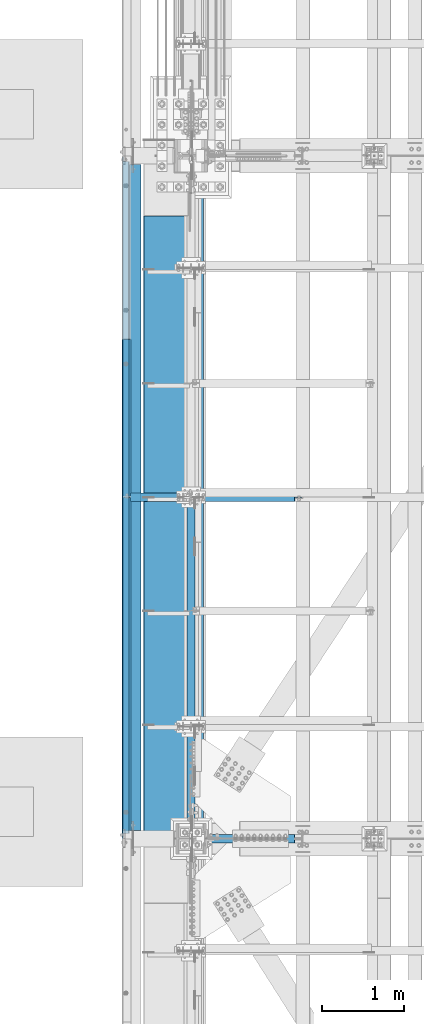
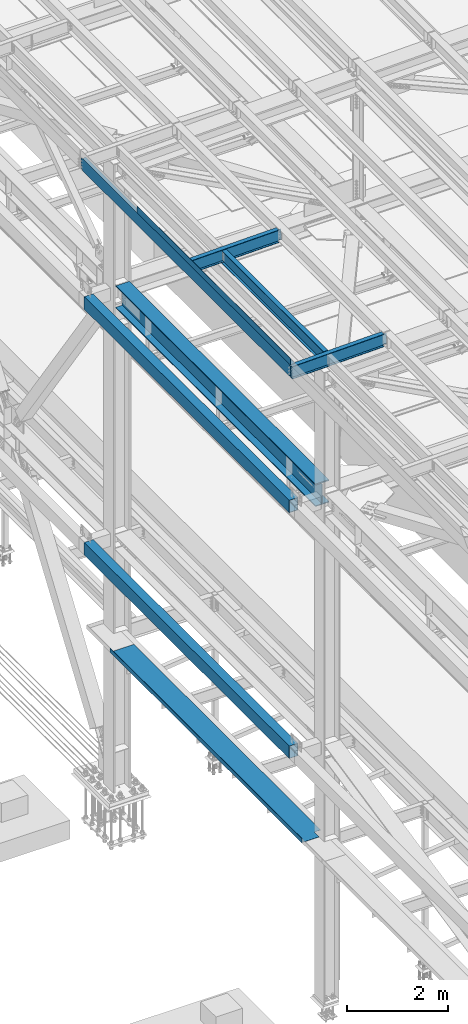
# One storey, part 1808 of 3843: 9 beams, 8 elements without a shape of their own.
"""IFC2X3 building model written with IfcOpenShell, lengths in millimetres."""

from ifc_helpers import new_model, si_unit, frame, origin_with_axes, place, context, subcontext, project, spatial, faceted_brep, material, type_object, element, aggregate, save


model = new_model("IFC2X3")

# Units and contexts
model_context = context("Model", 3, precision=1e-05, world=origin_with_axes())
body_context = subcontext(model_context, "Body", "Model", "MODEL_VIEW")
ifc_project = project(units=[si_unit("LENGTHUNIT", "METRE", prefix="MILLI"), si_unit("AREAUNIT", "SQUARE_METRE"), si_unit("VOLUMEUNIT", "CUBIC_METRE"), si_unit("MASSUNIT", "GRAM", prefix="KILO"), si_unit("TIMEUNIT", "SECOND"), si_unit("PLANEANGLEUNIT", "RADIAN"), si_unit("SOLIDANGLEUNIT", "STERADIAN"), si_unit("THERMODYNAMICTEMPERATUREUNIT", "DEGREE_CELSIUS"), si_unit("LUMINOUSINTENSITYUNIT", "LUMEN")], contexts=[model_context])

# Site, building, storey
site_placement = place(None, origin_with_axes())
site = spatial("IfcSite", under=ifc_project, at=site_placement, CompositionType="ELEMENT")
building_placement = place(site_placement, origin_with_axes())
building = spatial("IfcBuilding", under=site, at=building_placement, Name="Undefined", CompositionType="ELEMENT")
storey_placement = place(building_placement, origin_with_axes())
storey = spatial("IfcBuildingStorey", under=building, at=storey_placement, Name="Undefined", CompositionType="ELEMENT", Elevation=0.0)

# Assembly, beams
assembly_1_placement = place(storey_placement, origin_with_axes())
assembly_1 = element("IfcElementAssembly", 1, at=assembly_1_placement, inside=storey, Name="BEAM", AssemblyPlace="NOTDEFINED", PredefinedType="RIGID_FRAME")
ifc_material_1 = material(Name="STEEL/A572-50")
beam_type_1 = type_object("IfcBeamType", Name="C12X20.7", PredefinedType="NOTDEFINED")
beam_1_placement = place(assembly_1_placement, frame((35779.1150555403, 42202.0999999999, 45560.3009647411), z_axis=(-0.0211520980073474, 0.0, 0.999776269347241), x_axis=(0.0, 1.0, 0.0)))
beam_1 = element("IfcBeam", 2, at=beam_1_placement, type_object=beam_type_1, material=ifc_material_1, Name="BEAM", ObjectType="C12X20.7", context=body_context, shape_type="Brep", body=[
    faceted_brep([(15.8750000000582, 30.1624999998166, -126.999999999382), (15.8750003662499, 38.1000000000058, -127.000000023749), (53.975000190796, 38.0999999998094, -126.999999999396), (53.975000190796, 30.1624999998166, -126.999999999382), (58.8350797088351, 38.0999999998094, -127.96672992198), (58.8350797088351, 30.1624999998166, -127.966729921965), (62.955256176996, 38.0999999998021, -130.719743822439), (62.955256176996, 30.1624999998166, -130.719743822439), (65.7082700774772, 38.0999999997948, -134.839920290578), (65.7082700774772, 30.1624999998094, -134.6749274998), (66.6750000000611, 1.14757131086662e-06, -139.699999808552), (66.6750000000611, 38.0999999997948, -139.699999808603), (66.6750000000611, 38.0999999997803, -152.399999999783), (66.6750000000611, -38.1000000000931, -152.39999999971), (66.6750000000611, -38.1000000000931, -146.047459999718), (8289.92500000005, -38.0999999997948, 146.047459999805), (8289.92500000005, -38.0999999997875, 152.399999999798), (66.6750000000611, -38.0999999997875, 152.399999999798), (66.6750000000611, -38.0999999997948, 146.047459999805), (8289.92500000005, 38.1000000000859, 152.399999999725), (66.6750000000611, 38.1000000000859, 152.399999999725), (53.975000190796, 30.1625000000713, 126.999999999265), (53.975000190796, 38.100000000064, 126.999999999258), (15.8750006201954, 38.1000000000058, 126.999999975014), (15.8750000000582, 30.1625000000713, 126.999999999265), (58.8350797088351, 30.1625000000786, 127.966729921849), (58.8350797088351, 38.100000000064, 127.966729921842), (62.955256176996, 30.1625000000786, 130.719743822316), (62.955256176996, 38.1000000000568, 130.719743822301), (65.7082700774772, 30.1625000000786, 134.674927499756), (65.7082700774772, 38.1000000000713, 134.83992029044), (66.6750000000611, 1.1482770787552e-06, 139.699999808494), (66.6750000000611, 38.1000000000713, 139.699999808465), (8290.89172992263, 30.1625000000786, 134.674927499756), (8289.92500000005, 1.1482770787552e-06, 139.699999808494), (8289.92500000005, 38.1000000000713, 139.699999808465), (8290.89172992263, 38.1000000000713, 134.83992029044), (8293.64474382311, 30.1625000000786, 130.719743822316), (8293.64474382311, 38.1000000000568, 130.719743822301), (8297.76492029126, 30.1625000000786, 127.966729921849), (8297.76492029126, 38.100000000064, 127.966729921842), (8302.62499980931, 30.1625000000713, 126.999999999265), (8302.62499980931, 38.100000000064, 126.999999999258), (8340.72500000005, 30.1625000000713, 126.999999999265), (8340.72500000005, 38.100000000064, 126.999999999258), (8340.72500000005, 30.162500000064, 114.299999983516), (8340.72500000005, 30.1624999998385, -116.300000010502), (8340.72500000005, 30.1624999998166, -126.999999999382), (8340.72500000005, 38.0999999998094, -126.999999999396), (8302.62499980931, 30.1624999998166, -126.999999999382), (8302.62499980931, 38.0999999998094, -126.999999999396), (8297.76492029126, 30.1624999998166, -127.966729921965), (8297.76492029126, 38.0999999998094, -127.96672992198), (8293.64474382311, 30.1624999998166, -130.719743822439), (8293.64474382311, 38.0999999998021, -130.719743822439), (8290.89172992263, 30.1624999998094, -134.6749274998), (8290.89172992263, 38.0999999997948, -134.839920290578), (8289.92500000005, 1.14757131086662e-06, -139.699999808552), (8289.92500000005, 38.0999999997948, -139.699999808603), (8289.92500000005, -38.1000000000931, -146.047459999718), (8289.92500000005, -38.1000000000931, -152.39999999971), (8289.92500000005, 38.0999999997803, -152.399999999783), (15.8750000000582, 30.1624999998312, -116.299999999967), (15.8750000000582, 30.1625000000568, 114.299999994066)], [[[0, 1, 2, 3]], [[3, 2, 4, 5]], [[5, 4, 6, 7]], [[7, 6, 8, 9]], [[10, 11, 12, 13, 14]], [[9, 8, 11, 10]], [[15, 16, 17, 18]], [[16, 19, 20, 17]], [[21, 22, 23, 24]], [[25, 26, 22, 21]], [[27, 28, 26, 25]], [[29, 30, 28, 27]], [[31, 32, 30, 29]], [[17, 20, 32, 31, 18]], [[29, 33, 34, 15, 18, 31]], [[16, 15, 34, 35, 19]], [[33, 36, 35, 34]], [[37, 38, 36, 33]], [[39, 40, 38, 37]], [[41, 42, 40, 39]], [[43, 44, 42, 41]], [[44, 43, 45, 46, 47, 48]], [[47, 49, 50, 48]], [[51, 52, 50, 49]], [[53, 54, 52, 51]], [[55, 56, 54, 53]], [[57, 58, 56, 55]], [[59, 60, 61, 58, 57]], [[60, 59, 14, 13]], [[61, 60, 13, 12]], [[6, 4, 2, 1, 23, 22, 26, 28, 30, 32, 20, 19, 35, 36, 38, 40, 42, 44, 48, 50, 52, 54, 56, 58, 61, 12, 11, 8]], [[62, 63, 24, 23, 1, 0]], [[55, 53, 51, 49, 47, 46, 45, 43, 41, 39, 37, 33, 29, 27, 25, 21, 24, 63, 62, 0, 3, 5, 7, 9]], [[59, 57, 55, 9, 10, 14]]]),
])
ifc_material_2 = material(Name="STEEL/A36")
beam_type_2 = type_object("IfcBeamType", PredefinedType="NOTDEFINED")
beam_2_placement = place(assembly_1_placement, frame((35839.3101109972, 45265.975, 45717.1843160676), z_axis=(0.0, -1.0, 0.0), x_axis=(-0.999776270257024, 0.0, -0.0211520550054595)))
beam_2 = element("IfcBeam", 3, at=beam_2_placement, type_object=beam_type_2, material=ifc_material_2, Name="BENT_PLATE", context=body_context, shape_type="Brep", body=[
    faceted_brep([(-3.50355549016967e-07, -3.17499999742722, -3048.00000001723), (3.50421032635495e-07, -3.17500000260043, 3048.00000001724), (3.5035191103816e-07, 3.17499999739084, 3048.00000001724), (-3.50424670614302e-07, 3.17500000256405, -3048.00000001723), (101.599999864371, 3.17499999856227, 3048.00000000522), (101.599998739839, 3.17500000373548, -3048.00000002925), (95.249998765099, -3.17499999632128, -3048.00000002851), (95.2499998896274, -3.17500000149448, 3048.00000000597), (101.600000309205, -161.925000875126, 3047.9999999938), (101.599999608374, -161.925000446165, -3048.00000004067), (95.2500003092064, -161.925000900388, 3047.99999999456), (95.2499996083752, -161.925000471427, -3048.00000003992)], [[[0, 1, 2, 3]], [[3, 2, 4, 5]], [[1, 0, 6, 7]], [[5, 4, 8, 9]], [[4, 2, 1, 7, 10, 8]], [[7, 6, 11, 10]], [[6, 0, 3, 5, 9, 11]], [[10, 11, 9, 8]]]),
])
aggregate(assembly_1, [beam_2, beam_1])

# Assembly, beam
assembly_2_placement = place(storey_placement, origin_with_axes())
assembly_2 = element("IfcElementAssembly", 4, at=assembly_2_placement, inside=storey, Name="BEAM", AssemblyPlace="NOTDEFINED", PredefinedType="RIGID_FRAME")
ifc_material_3 = material(Name="STEEL/A992")
beam_type_3 = type_object("IfcBeamType", Name="W21X101", PredefinedType="NOTDEFINED")
beam_3_placement = place(assembly_2_placement, frame((36576.0, 42202.1, 42197.3375), z_axis=(0.0, 0.0, 1.0), x_axis=(0.0, 1.0, 0.0)))
beam_3 = element("IfcBeam", 5, at=beam_3_placement, type_object=beam_type_3, material=ifc_material_3, Name="BEAM", ObjectType="W21X101", context=body_context, shape_type="Brep", body=[
    faceted_brep([(8143.87499999999, 155.574999999997, -271.462500000001), (8143.87499999999, 147.637499999997, -271.462500000001), (8143.87499999999, -147.637499999997, -271.462500000001), (8143.87499999999, -155.574999999997, -271.462500000001), (198.4375, -155.574999999997, -271.462500000001), (198.4375, 155.574999999997, -271.462500000001), (8143.87499999999, -155.574999999997, -250.824999999997), (198.4375, -155.574999999997, -250.824999999997), (277.464930772214, -6.34999999999127, 217.357163726287), (277.464930772214, 6.35000000000582, 217.357163726287), (272.401765581464, 6.35000000000582, 215.900000000001), (272.401765581464, -6.34999999999127, 215.900000000001), (280.978938807766, -6.34999999999127, 221.282812131351), (280.978938807766, 6.35000000000582, 221.282812131351), (281.868622181899, -6.34999999999127, 226.475829690324), (281.868622181899, 6.35000000000582, 226.475829690324), (279.861767898796, -6.34999999999127, 231.347328818971), (279.861767898796, 6.35000000000582, 231.347328818971), (275.572405435074, -6.34999999999127, 234.406795689014), (275.572405435074, 6.35000000000582, 234.406795689014), (230.187500000004, -6.34999999999127, 250.428), (230.187500000004, 6.35000000000582, 250.428), (195.262500000001, -6.35000000000582, 250.428), (195.262500000001, 6.35000000000582, 250.428), (195.262500000001, -6.35000000000582, 250.824999999997), (195.262500000001, 6.35000000000582, 250.824999999997), (8143.87499999999, -155.574999999997, 271.462500000001), (8143.87499999999, -147.637499999997, 271.462500000001), (8143.87499999999, 147.637499999997, 271.462500000001), (8143.87499999999, 155.574999999997, 271.462500000001), (207.177101116094, 155.574999999997, 271.462500000001), (207.177101116094, -155.574999999997, 271.462500000001), (8143.87499999999, 155.574999999997, 250.824999999997), (195.262500000001, 155.574999999997, 250.824999999997), (8143.87499999999, 147.637499999997, 250.824999999997), (8143.87499999999, 6.34999999999854, 250.824999999997), (8143.87499999999, 6.34999999999854, -250.824999999997), (8143.87499999999, 147.637499999997, -250.824999999997), (8143.87499999999, 155.574999999997, -250.824999999997), (198.4375, 155.574999999997, -250.824999999997), (198.4375, 6.34999999999854, -250.824999999997), (198.4375, 6.34999999999854, 215.900000000001), (198.4375, -6.34999999999854, 215.900000000001), (8143.87499999999, -6.34999999999854, -250.824999999997), (8143.87499999999, -6.34999999999854, -180.127499999995), (8143.87499999999, -6.34999999999854, 215.052499999998), (8143.87499999999, -6.34999999999854, 250.824999999997), (198.4375, -6.34999999999854, -250.824999999997), (8143.87499999999, -147.637499999997, -250.824999999997), (8143.87499999999, -155.574999999997, 250.824999999997), (8143.87499999999, -147.637499999997, 250.824999999997), (195.262500000001, -155.574999999997, 250.824999999997)], [[[0, 1, 2, 3, 4, 5]], [[3, 6, 7, 4]], [[8, 9, 10, 11]], [[12, 13, 9, 8]], [[14, 15, 13, 12]], [[16, 17, 15, 14]], [[18, 19, 17, 16]], [[20, 21, 19, 18]], [[21, 20, 22, 23]], [[23, 22, 24, 25]], [[26, 27, 28, 29, 30, 31]], [[29, 32, 33, 30]], [[32, 34, 35, 25, 33]], [[36, 37, 38, 39, 40]], [[10, 9, 13, 15, 17, 19, 21, 23, 25, 35, 36, 40, 41]], [[11, 10, 41, 42]], [[43, 44, 45, 46, 24, 22, 20, 18, 16, 14, 12, 8, 11, 42, 47]], [[6, 48, 43, 47, 7]], [[42, 41, 40, 39, 5, 4, 7, 47]], [[38, 0, 5, 39]], [[37, 36, 35, 34, 32, 29, 28, 27, 26, 49, 50, 46, 45, 44, 43, 48, 6, 3, 2, 1, 0, 38]], [[46, 50, 49, 51, 24]], [[31, 30, 33, 25, 24, 51]], [[49, 26, 31, 51]]]),
])
aggregate(assembly_2, [beam_3])

assembly_3_placement = place(storey_placement, origin_with_axes())
assembly_3 = element("IfcElementAssembly", 6, at=assembly_3_placement, inside=storey, Name="GIRT", AssemblyPlace="NOTDEFINED", PredefinedType="RIGID_FRAME")
ifc_material_4 = material()
beam_type_4 = type_object("IfcBeamType", Name="HSS12X8X3/8", PredefinedType="NOTDEFINED")
beam_4_placement = place(assembly_3_placement, frame((35861.625, 42202.1, 42214.8), z_axis=(0.0, 0.0, 1.0), x_axis=(0.0, 1.0, 0.0)))
beam_4 = element("IfcBeam", 7, at=beam_4_placement, type_object=beam_type_4, material=ifc_material_4, Name="GIRT", ObjectType="HSS12X8X3/8", context=body_context, shape_type="Brep", body=[
    faceted_brep([(8253.41249999999, 101.599999999999, -152.400000000001), (8253.41249999999, -101.599999999999, -152.400000000001), (103.1875, -101.600000000006, -152.400000000001), (103.1875, 101.600000000006, -152.400000000001), (8253.41249999999, -101.599999999999, 152.400000000001), (103.1875, -101.600000000006, 152.400000000001), (8253.41249999999, 101.599999999999, 152.400000000001), (103.1875, 101.600000000006, 152.400000000001), (103.1875, 92.0749999999971, -142.875), (103.1875, 92.0749999999971, 142.875), (103.1875, -92.0749999999971, 142.875), (103.1875, -92.0749999999971, -142.875), (8253.41249999999, -92.0749999999971, 142.875), (8253.41249999999, -92.0749999999971, -142.875), (8253.41249999999, 92.0749999999971, -142.875), (8253.41249999999, 92.0749999999971, 142.875)], [[[0, 1, 2, 3]], [[1, 4, 5, 2]], [[4, 6, 7, 5]], [[6, 0, 3, 7]], [[3, 2, 5, 7], [8, 9, 10, 11]], [[12, 13, 11, 10]], [[13, 14, 8, 11]], [[14, 15, 9, 8]], [[15, 12, 10, 9]], [[0, 6, 4, 1], [14, 13, 12, 15]]]),
])
aggregate(assembly_3, [beam_4])

assembly_4_placement = place(storey_placement, origin_with_axes())
assembly_4 = element("IfcElementAssembly", 8, at=assembly_4_placement, inside=storey, Name="GIRT", AssemblyPlace="NOTDEFINED", PredefinedType="RIGID_FRAME")
beam_5_placement = place(assembly_4_placement, frame((35861.625, 42202.1, 36252.15), z_axis=(0.0, 0.0, 1.0), x_axis=(0.0, 1.0, 0.0)))
beam_5 = element("IfcBeam", 9, at=beam_5_placement, type_object=beam_type_4, material=ifc_material_4, Name="GIRT", ObjectType="HSS12X8X3/8", context=body_context, shape_type="Brep", body=[
    faceted_brep([(8253.41249999999, 101.599999999999, -152.400000000001), (8253.41249999999, -101.599999999999, -152.400000000001), (103.1875, -101.600000000006, -152.400000000001), (103.1875, 101.600000000006, -152.400000000001), (8253.41249999999, 101.599999999999, 152.400000000001), (103.1875, 101.600000000006, 152.400000000001), (8253.41249999999, -101.599999999999, 152.400000000001), (103.1875, -101.600000000006, 152.400000000001), (8253.41249999999, 92.0749999999971, -142.875), (8253.41249999999, -92.0749999999971, -142.875), (8253.41249999999, -92.0749999999971, 142.875), (8253.41249999999, 92.0749999999971, 142.875), (103.1875, -92.0749999999971, 142.875), (103.1875, 92.0749999999971, 142.875), (103.1875, 92.0749999999971, -142.875), (103.1875, -92.0749999999971, -142.875)], [[[0, 1, 2, 3]], [[4, 0, 3, 5]], [[6, 4, 5, 7]], [[1, 6, 7, 2]], [[0, 4, 6, 1], [8, 9, 10, 11]], [[11, 10, 12, 13]], [[8, 11, 13, 14]], [[9, 8, 14, 15]], [[10, 9, 15, 12]], [[3, 2, 7, 5], [14, 13, 12, 15]]]),
])
aggregate(assembly_4, [beam_5])

assembly_5_placement = place(storey_placement, origin_with_axes())
assembly_5 = element("IfcElementAssembly", 10, at=assembly_5_placement, inside=storey, Name="BEAM", AssemblyPlace="NOTDEFINED", PredefinedType="RIGID_FRAME")
beam_type_5 = type_object("IfcBeamType", Name="W12X19", PredefinedType="NOTDEFINED")
beam_6_placement = place(assembly_5_placement, frame((36575.9999999361, 42202.1, 45575.6071293687), z_axis=(0.0, 0.0, 1.0), x_axis=(0.0, 1.0, 0.0)))
beam_6 = element("IfcBeam", 11, at=beam_6_placement, type_object=beam_type_5, material=ifc_material_3, Name="BEAM", ObjectType="W12X19", context=body_context, shape_type="Brep", body=[
    faceted_brep([(15.8750000000146, -3.17500000000291, -128.587499998961), (15.8750000000146, 3.17500000000291, -128.587499998961), (53.9750001907523, 3.17500000000291, -128.587499998961), (53.9750001907523, -3.17500000000291, -128.587499998961), (58.8350797087915, 3.17500000000291, -129.554229921552), (58.8350797087915, -3.17500000000291, -129.554229921552), (62.9552561769524, 3.17500000000291, -132.307243822026), (62.9552561769524, -3.17500000000291, -132.307243822026), (65.7082700774336, 3.17500000000291, -136.42742029018), (65.7082700774336, -3.17500000000291, -136.42742029018), (66.6750000000175, -3.17500000000291, -141.287499808226), (66.6750000000175, 3.17500000000291, -141.287499808226), (66.6750000000175, 3.17500000000291, -144.462500000001), (66.6750000000175, 50.8000000000029, -144.462500000001), (66.6750000000175, 50.8000000000029, -153.987500000003), (66.6750000000175, -50.8000000000029, -153.987500000003), (66.6750000000175, -50.8000000000029, -144.462500000001), (66.6750000000175, -3.17500000000291, -144.462500000001), (4111.62499999991, 50.8000000000029, 144.462500000001), (4111.62499999991, 3.17500000000291, 144.462500000001), (66.6750000000175, 3.17500000000291, 144.462500000001), (66.6750000000175, 50.8000000000029, 144.462500000001), (53.9750001907523, -3.17500000000291, 128.587500001042), (53.9750001907523, 3.17500000000291, 128.587500001042), (15.8750000000146, 3.17500000000291, 128.587500001042), (15.8750000000146, -3.17500000000291, 128.587500001042), (58.8350797087915, -3.17500000000291, 129.554229923633), (58.8350797087915, 3.17500000000291, 129.554229923633), (62.9552561769524, -3.17500000000291, 132.307243824107), (62.9552561769524, 3.17500000000291, 132.307243824107), (65.7082700774336, -3.17500000000291, 136.427420292261), (65.7082700774336, 3.17500000000291, 136.427420292261), (66.6750000000175, -3.17500000000291, 141.287499810307), (66.6750000000175, 3.17500000000291, 141.287499810307), (4111.62499999991, -50.8000000000029, 153.987500000003), (4111.62499999991, 50.8000000000029, 153.987500000003), (66.6750000000175, 50.8000000000029, 153.987500000003), (66.6750000000175, -50.8000000000029, 153.987500000003), (4111.62499999991, -50.8000000000029, 144.462500000001), (66.6750000000175, -50.8000000000029, 144.462500000001), (4111.62499999991, -3.17500000000291, 144.462500000001), (66.6750000000175, -3.17500000000291, 144.462500000001), (4111.62499999991, -3.17500000000291, 141.287499810329), (4111.62499999991, 3.17500000000291, 141.287499810329), (4112.5917299225, -3.17500000000291, 136.427420292282), (4112.5917299225, 3.17500000000291, 136.427420292282), (4115.34474382298, -3.17500000000291, 132.307243824129), (4115.34474382298, 3.17500000000291, 132.307243824129), (4119.46492029114, -3.17500000000291, 129.554229923655), (4119.46492029114, 3.17500000000291, 129.554229923655), (4124.32499980918, -3.17500000000291, 128.587500001064), (4124.32499980918, 3.17500000000291, 128.587500001064), (4162.42499999992, -3.17500000000291, 128.587500001064), (4162.42499999992, 3.17500000000291, 128.587500001064), (4162.42499999992, 3.17500000000291, -114.712499998423), (4162.42499999992, 3.17500000000291, 115.887500001576), (4162.42499999992, -3.17500000000291, -128.587499998939), (4162.42499999992, 3.17500000000291, -128.587499998939), (4124.32499980918, -3.17500000000291, -128.587499998939), (4124.32499980918, 3.17500000000291, -128.587499998939), (4119.46492029114, -3.17500000000291, -129.55422992153), (4119.46492029114, 3.17500000000291, -129.55422992153), (4115.34474382298, -3.17500000000291, -132.307243822004), (4115.34474382298, 3.17500000000291, -132.307243822004), (4112.5917299225, -3.17500000000291, -136.427420290158), (4112.5917299225, 3.17500000000291, -136.427420290158), (4111.62499999991, -3.17500000000291, -141.287499808204), (4111.62499999991, 3.17500000000291, -141.287499808204), (4111.62499999991, -3.17500000000291, -144.462500000001), (4111.62499999991, -50.8000000000029, -144.462500000001), (4111.62499999991, -50.8000000000029, -153.987500000003), (4111.62499999991, 50.8000000000029, -153.987500000003), (4111.62499999991, 50.8000000000029, -144.462500000001), (4111.62499999991, 3.17500000000291, -144.462500000001), (15.8750000000146, 3.17500000000291, -114.712499998386), (15.8750000000146, 3.17500000000291, 115.887500001612)], [[[0, 1, 2, 3]], [[3, 2, 4, 5]], [[5, 4, 6, 7]], [[7, 6, 8, 9]], [[10, 11, 12, 13, 14, 15, 16, 17]], [[9, 8, 11, 10]], [[18, 19, 20, 21]], [[22, 23, 24, 25]], [[26, 27, 23, 22]], [[28, 29, 27, 26]], [[30, 31, 29, 28]], [[32, 33, 31, 30]], [[34, 35, 36, 37]], [[38, 34, 37, 39]], [[40, 38, 39, 41]], [[37, 36, 21, 20, 33, 32, 41, 39]], [[35, 18, 21, 36]], [[34, 38, 40, 42, 43, 19, 18, 35]], [[44, 45, 43, 42]], [[46, 47, 45, 44]], [[48, 49, 47, 46]], [[50, 51, 49, 48]], [[52, 53, 51, 50]], [[54, 55, 53, 52, 56, 57]], [[56, 58, 59, 57]], [[60, 61, 59, 58]], [[62, 63, 61, 60]], [[64, 65, 63, 62]], [[66, 67, 65, 64]], [[68, 69, 70, 71, 72, 73, 67, 66]], [[69, 68, 17, 16]], [[70, 69, 16, 15]], [[71, 70, 15, 14]], [[72, 71, 14, 13]], [[73, 72, 13, 12]], [[6, 4, 2, 1, 74, 75, 24, 23, 27, 29, 31, 33, 20, 19, 43, 45, 47, 49, 51, 53, 55, 54, 57, 59, 61, 63, 65, 67, 73, 12, 11, 8]], [[25, 24, 75, 74, 1, 0]], [[68, 66, 64, 62, 60, 58, 56, 52, 50, 48, 46, 44, 42, 40, 41, 32, 30, 28, 26, 22, 25, 0, 3, 5, 7, 9, 10, 17]]]),
])
aggregate(assembly_5, [beam_6])

assembly_6_placement = place(storey_placement, origin_with_axes())
assembly_6 = element("IfcElementAssembly", 12, at=assembly_6_placement, inside=storey, Name="BEAM", AssemblyPlace="NOTDEFINED", PredefinedType="RIGID_FRAME")
beam_7_placement = place(assembly_6_placement, frame((35741.5458529605, 42202.1, 45557.9190402458), z_axis=(-0.0243256950121359, 0.0, 0.999704086498688), x_axis=(0.999704086498688, 0.0, 0.0243256950121354)))
beam_7 = element("IfcBeam", 13, at=beam_7_placement, type_object=beam_type_5, material=ifc_material_3, Name="BEAM", ObjectType="W12X19", context=body_context, shape_type="Brep", body=[
    faceted_brep([(2104.49797748839, -3.17500000000291, -144.462499999107), (2104.49797748839, -50.8000000000029, -144.462499999107), (2104.46774104469, -50.8000000000029, -153.987499999101), (2104.46774104469, 50.8000000000029, -153.987499999101), (2104.49797748839, 50.8000000000029, -144.462499999107), (2104.49797748839, 3.17500000000291, -144.462499999107), (2104.50908314079, 3.17500000000291, -140.964028417897), (2104.50908314079, -3.17500000000291, -140.964028417897), (2105.49123609599, 3.17500000000291, -136.107042187999), (2105.49123609599, -3.17500000000291, -136.107042187999), (2108.25731527051, 3.17500000000291, -131.995625684518), (2108.25731527051, -3.17500000000291, -131.995625684518), (2112.38621018458, 3.17500000000291, -129.255704800016), (2112.38621018458, -3.17500000000291, -129.255704800016), (2117.24933401607, 3.17500000000291, -128.304407651711), (2117.24933401607, -3.17500000000291, -128.304407651711), (2187.09898225182, -3.17500000000291, -128.526140455615), (2187.09898225182, 3.17500000000291, -128.526140455615), (4.36557456851006e-11, 3.17500000000291, 144.462499999994), (4.36557456851006e-11, 50.8000000000029, 144.462499999994), (2105.41514961354, 50.8000000000029, 144.462500000773), (2105.41514961354, 3.17500000000291, 144.462500000773), (-3.63797880709171e-11, -50.8000000000029, -153.987499999988), (-3.63797880709171e-11, -50.8000000000029, -144.46249999998), (-3.63797880709171e-11, -3.17500000000291, -144.46249999998), (4.36557456851006e-11, -3.17500000000291, 144.462499999994), (4.36557456851006e-11, -50.8000000000029, 144.462499999994), (3.63797880709171e-11, -50.8000000000029, 153.987499999988), (3.63797880709171e-11, 50.8000000000029, 153.987499999988), (-3.63797880709171e-11, 3.17500000000291, -144.46249999998), (-3.63797880709171e-11, 50.8000000000029, -144.46249999998), (-3.63797880709171e-11, 50.8000000000029, -153.987499999988), (2105.41514961354, -3.17500000000291, 144.462500000773), (2105.41514961354, -50.8000000000029, 144.462500000773), (2105.44538605725, -50.8000000000029, 153.987500000767), (2105.44538605725, 50.8000000000029, 153.987500000767), (2105.406093116, -3.17500000000291, 141.60954745319), (2105.406093116, 3.17500000000291, 141.60954745319), (2106.3573902643, -3.17500000000291, 136.746423621691), (2106.3573902643, 3.17500000000291, 136.746423621691), (2109.09731114881, -3.17500000000291, 132.617528707618), (2109.09731114881, 3.17500000000291, 132.617528707618), (2113.20872765229, -3.17500000000291, 129.851449533111), (2113.20872765229, 3.17500000000291, 129.851449533111), (2118.06571388218, -3.17500000000291, 128.869296577905), (2118.06571388218, 3.17500000000291, 128.869296577905), (2187.91536211891, -3.17500000000291, 128.647563774), (2187.91536211891, 3.17500000000291, 128.647563774)], [[[0, 1, 2, 3, 4, 5, 6, 7]], [[7, 6, 8, 9]], [[9, 8, 10, 11]], [[11, 10, 12, 13]], [[13, 12, 14, 15]], [[16, 15, 14, 17]], [[18, 19, 20, 21]], [[22, 23, 24, 25, 26, 27, 28, 19, 18, 29, 30, 31]], [[26, 25, 32, 33]], [[27, 26, 33, 34]], [[28, 27, 34, 35]], [[19, 28, 35, 20]], [[34, 33, 32, 36, 37, 21, 20, 35]], [[38, 39, 37, 36]], [[40, 41, 39, 38]], [[42, 43, 41, 40]], [[44, 45, 43, 42]], [[46, 47, 45, 44]], [[47, 46, 16, 17]], [[12, 10, 8, 6, 5, 29, 18, 21, 37, 39, 41, 43, 45, 47, 17, 14]], [[30, 29, 5, 4]], [[31, 30, 4, 3]], [[22, 31, 3, 2]], [[23, 22, 2, 1]], [[24, 23, 1, 0]], [[46, 44, 42, 40, 38, 36, 32, 25, 24, 0, 7, 9, 11, 13, 15, 16]]]),
])
aggregate(assembly_6, [beam_7])

assembly_7_placement = place(storey_placement, origin_with_axes())
assembly_7 = element("IfcElementAssembly", 14, at=assembly_7_placement, inside=storey, Name="BEAM", AssemblyPlace="NOTDEFINED", PredefinedType="RIGID_FRAME")
beam_8_placement = place(assembly_7_placement, frame((35741.0571586919, 46380.3999999999, 45557.9079249889), z_axis=(-0.0211520980073474, 0.0, 0.999776269347241), x_axis=(0.999776270257024, 0.0, 0.0211520550054619)))
beam_8 = element("IfcBeam", 15, at=beam_8_placement, type_object=beam_type_5, material=ifc_material_3, Name="BEAM", ObjectType="W12X19", context=body_context, shape_type="Brep", body=[
    faceted_brep([(20.6374979119428, -3.17500000000291, -128.587500021946), (20.6374979119428, 3.17500000000291, -128.587500021946), (84.1374979491229, 3.17500000000291, -128.587500085479), (84.1374979491229, -3.17500000000291, -128.587500085479), (88.9975774661289, 3.17500000000291, -129.554230012938), (88.9975774661289, -3.17500000000291, -129.554230012938), (93.1177539315104, 3.17500000000291, -132.307243917545), (93.1177539315104, -3.17500000000291, -132.307243917545), (95.8707678278151, 3.17500000000291, -136.427420388471), (95.8707678278151, -3.17500000000291, -136.427420388471), (96.8374977455387, -3.17500000000291, -141.287499907492), (96.8374977455387, 3.17500000000291, -141.287499907492), (96.8374977423518, 3.17500000000291, -144.462499999776), (96.8374977423518, 50.8000000000029, -144.462499999776), (96.8374977328203, 50.8000000000029, -153.987499999792), (96.8374977328203, -50.8000000000029, -153.987499999792), (96.8374977423518, -50.8000000000029, -144.462499999776), (96.8374977423518, -3.17500000000291, -144.462499999776), (2105.41084938969, 50.8000000000029, 144.462500001886), (2105.41084938969, 3.17500000000291, 144.462500001886), (96.8374980314547, 3.17500000000291, 144.462500000489), (96.8374980314547, 50.8000000000029, 144.462500000489), (84.1374982064444, -3.17500000000291, 128.587499915513), (84.1374982064444, 3.17500000000291, 128.587499915513), (20.637499711811, 3.17500000000291, 128.587499979069), (20.637499711811, -3.17500000000291, 128.587499979069), (88.9975777254003, -3.17500000000291, 129.554229833244), (88.9975777254003, 3.17500000000291, 129.554229833244), (93.1177541962679, -3.17500000000291, 132.307243729607), (93.1177541962679, 3.17500000000291, 132.307243729607), (95.8707681008382, -3.17500000000291, 136.427420195025), (95.8707681008382, 3.17500000000291, 136.427420195025), (96.8374980282824, -3.17500000000291, 141.287499712118), (96.8374980282824, 3.17500000000291, 141.287499712118), (2105.41084938969, -50.8000000000029, 153.987500001873), (2105.41084938969, 50.8000000000029, 153.987500001873), (96.8374980410008, 50.8000000000029, 153.987500000498), (96.8374980410154, -50.8000000000029, 153.987499285155), (2105.41084938969, -50.8000000000029, 144.462500001886), (96.8374980314547, -50.8000000000029, 144.462500000489), (2105.41084938969, -3.17500000000291, 144.462500001886), (96.8374980314547, -3.17500000000291, 144.462500000489), (2105.41084938969, -3.17500000000291, 141.287499822982), (2105.41084938969, 3.17500000000291, 141.287499822982), (2106.37757931228, -3.17500000000291, 136.427420304964), (2106.37757931228, 3.17500000000291, 136.427420304964), (2109.13059321276, -3.17500000000291, 132.307243836833), (2109.13059321276, 3.17500000000291, 132.307243836833), (2113.2507696809, -3.17500000000291, 129.554229936373), (2113.2507696809, 3.17500000000291, 129.554229936373), (2118.11084919891, -3.17500000000291, 128.587500013789), (2118.11084919891, 3.17500000000291, 128.587500013789), (2187.96084387035, -3.17500000000291, 128.587500013869), (2187.96085492185, 3.17500000000291, 128.587500013869), (2187.96084387035, -3.17500000000291, 115.88749999088), (2187.96084387035, -3.17500000000291, -114.712500011075), (2187.96084387035, -3.17500000000291, -128.587499987319), (2187.96085492185, 3.17500000000291, -128.587499987319), (2118.11093761956, -3.17500000000291, -128.587499987378), (2118.11093761956, 3.17500000000291, -128.587499987378), (2113.25085810155, -3.17500000000291, -129.554229909969), (2113.25085810155, 3.17500000000291, -129.554229909969), (2109.13068163341, -3.17500000000291, -132.307243810443), (2109.13068163341, 3.17500000000291, -132.307243810443), (2106.37766773295, -3.17500000000291, -136.427420278582), (2106.37766773295, 3.17500000000291, -136.427420278582), (2105.41093781037, -3.17500000000291, -141.287499796599), (2105.41093781037, 3.17500000000291, -141.287499796599), (2105.41093781037, -3.17500000000291, -144.462499997644), (2105.41093781037, -50.8000000000029, -144.462499997644), (2105.41093781039, -50.8000000000029, -153.987499997624), (2105.41093781039, 50.8000000000029, -153.987499997624), (2105.41093781037, 50.8000000000029, -144.462499997644), (2105.41093781037, 3.17500000000291, -144.462499997644), (20.6374980090477, 3.17500000000291, -114.712499752241), (20.6374996229279, 3.17500000000291, 115.88750024372)], [[[0, 1, 2, 3]], [[3, 2, 4, 5]], [[5, 4, 6, 7]], [[7, 6, 8, 9]], [[10, 11, 12, 13, 14, 15, 16, 17]], [[9, 8, 11, 10]], [[18, 19, 20, 21]], [[22, 23, 24, 25]], [[26, 27, 23, 22]], [[28, 29, 27, 26]], [[30, 31, 29, 28]], [[32, 33, 31, 30]], [[34, 35, 36, 37]], [[38, 34, 37, 39]], [[40, 38, 39, 41]], [[37, 36, 21, 20, 33, 32, 41, 39]], [[35, 18, 21, 36]], [[34, 38, 40, 42, 43, 19, 18, 35]], [[44, 45, 43, 42]], [[46, 47, 45, 44]], [[48, 49, 47, 46]], [[50, 51, 49, 48]], [[52, 53, 51, 50]], [[53, 52, 54, 55, 56, 57]], [[56, 58, 59, 57]], [[60, 61, 59, 58]], [[62, 63, 61, 60]], [[64, 65, 63, 62]], [[66, 67, 65, 64]], [[68, 69, 70, 71, 72, 73, 67, 66]], [[69, 68, 17, 16]], [[70, 69, 16, 15]], [[71, 70, 15, 14]], [[72, 71, 14, 13]], [[73, 72, 13, 12]], [[6, 4, 2, 1, 74, 75, 24, 23, 27, 29, 31, 33, 20, 19, 43, 45, 47, 49, 51, 53, 57, 59, 61, 63, 65, 67, 73, 12, 11, 8]], [[25, 24, 75, 74, 1, 0]], [[68, 66, 64, 62, 60, 58, 56, 55, 54, 52, 50, 48, 46, 44, 42, 40, 41, 32, 30, 28, 26, 22, 25, 0, 3, 5, 7, 9, 10, 17]]]),
])
aggregate(assembly_7, [beam_8])

assembly_8_placement = place(storey_placement, origin_with_axes())
assembly_8 = element("IfcElementAssembly", 16, at=assembly_8_placement, inside=storey, Name="BEAM", AssemblyPlace="NOTDEFINED", PredefinedType="RIGID_FRAME")
beam_type_6 = type_object("IfcBeamType", PredefinedType="NOTDEFINED")
beam_9_placement = place(assembly_8_placement, frame((36537.9000000002, 46015.2755, 34039.175), z_axis=(0.0, -1.0, 0.0), x_axis=(-1.0, 0.0, 0.0)))
beam_9 = element("IfcBeam", 17, at=beam_9_placement, type_object=beam_type_6, material=ifc_material_2, Name="BENT_PLATE", context=body_context, shape_type="Brep", body=[
    faceted_brep([(152.400000000205, -3.17500000000291, 3614.73800000003), (152.400000000205, 3.17500000000291, 3614.73800000003), (0.0, 3.17500000000291, 3614.73800000003), (0.0, -3.17500000000291, 3614.73800000003), (152.400000000205, -3.17500000000291, 3810.00000000003), (152.400000000205, 3.17500000000291, 3810.0), (539.749975586143, -3.17500000000291, -3810.0), (0.0, -3.17500000000291, -3810.0), (0.0, 3.17500000000291, -3810.0), (546.099973958539, 3.17500000000291, -3810.0), (546.10000000021, -98.424998372182, -3810.0), (539.750000000204, -98.4249999997846, -3810.0), (546.099973958539, 3.17500000000291, 3810.0), (546.10000000021, -98.424998372182, 3810.0), (539.750000000204, -98.4249999997846, 3810.0), (539.749975586143, -3.17500000000291, 3810.0)], [[[0, 1, 2, 3]], [[4, 5, 1, 0]], [[6, 7, 8, 9, 10, 11]], [[9, 12, 13, 10]], [[14, 11, 10, 13]], [[15, 6, 11, 14]], [[3, 7, 6, 15, 4, 0]], [[8, 7, 3, 2]], [[12, 9, 8, 2, 1, 5]], [[15, 14, 13, 12, 5, 4]]]),
])
aggregate(assembly_8, [beam_9])

save(model, "model.ifc")
